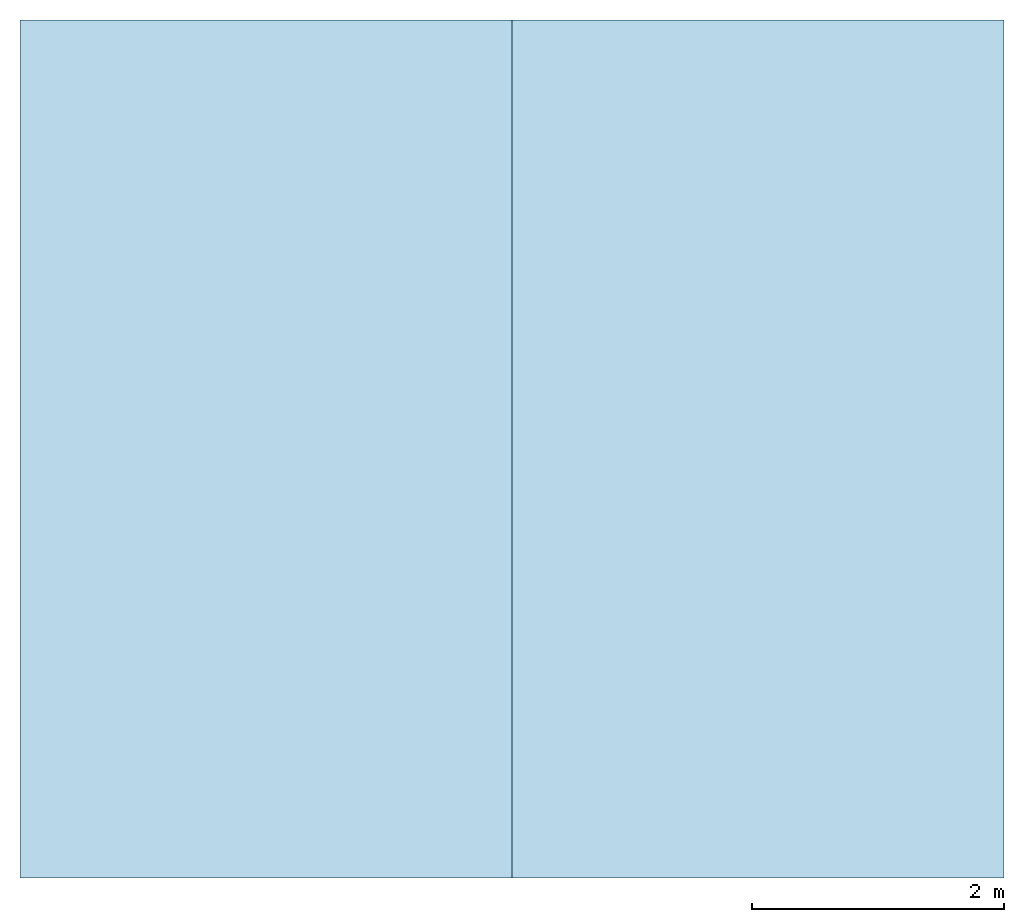
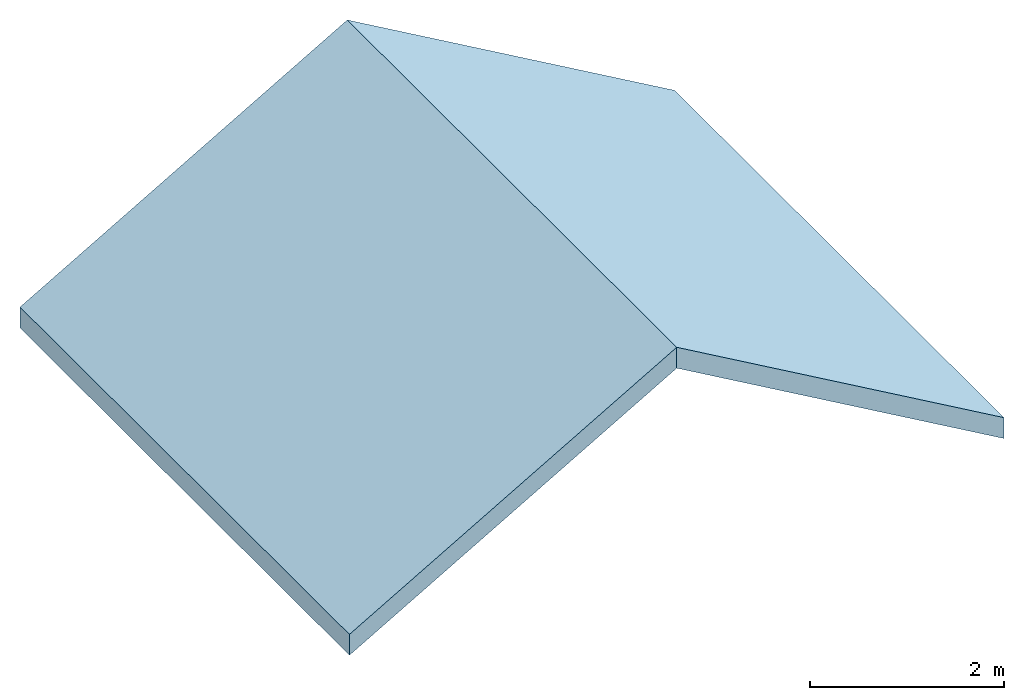
# One storey: 2 slabs, 1 element without a shape of its own.
"""IFC2X3 building model written with IfcOpenShell, lengths in millimetres."""

from ifc_helpers import new_model, entity, si_unit, converted_unit, derived_unit, direction, frame, frame_2d, origin, place, context, subcontext, project, spatial, rectangle, extrude, material, layer, layer_set, element, aggregate, save


model = new_model("IFC2X3")

# Units and contexts
model_context = context("Model", 3, precision=0.01, world=origin(), true_north=direction((6.12303176911189e-17, 1.0)))
body_context = subcontext(model_context, "Body", "Model", "MODEL_VIEW")
ifc_project = project(units=[si_unit("LENGTHUNIT", "METRE", prefix="MILLI"), si_unit("AREAUNIT", "SQUARE_METRE"), si_unit("VOLUMEUNIT", "CUBIC_METRE"), converted_unit("PLANEANGLEUNIT", "DEGREE", entity("IfcRatioMeasure", 0.0174532925199433), si_unit("PLANEANGLEUNIT", "RADIAN"), dimensions=[0, 0, 0, 0, 0, 0, 0]), si_unit("MASSUNIT", "GRAM", prefix="KILO"), si_unit("TIMEUNIT", "SECOND"), si_unit("FREQUENCYUNIT", "HERTZ"), si_unit("THERMODYNAMICTEMPERATUREUNIT", "DEGREE_CELSIUS"), derived_unit("THERMALTRANSMITTANCEUNIT", [(si_unit("MASSUNIT", "GRAM", prefix="KILO"), 1), (si_unit("THERMODYNAMICTEMPERATUREUNIT", "KELVIN"), -1), (si_unit("TIMEUNIT", "SECOND"), -3)]), derived_unit("VOLUMETRICFLOWRATEUNIT", [(si_unit("LENGTHUNIT", "METRE"), 3), (si_unit("TIMEUNIT", "SECOND"), -1)]), si_unit("ELECTRICCURRENTUNIT", "AMPERE"), si_unit("ELECTRICVOLTAGEUNIT", "VOLT"), si_unit("POWERUNIT", "WATT"), si_unit("FORCEUNIT", "NEWTON", prefix="KILO"), si_unit("ILLUMINANCEUNIT", "LUX"), si_unit("LUMINOUSFLUXUNIT", "LUMEN"), si_unit("LUMINOUSINTENSITYUNIT", "CANDELA"), derived_unit("USERDEFINED", [(si_unit("MASSUNIT", "GRAM", prefix="KILO"), -1), (si_unit("LENGTHUNIT", "METRE"), -2), (si_unit("TIMEUNIT", "SECOND"), 3), (si_unit("LUMINOUSFLUXUNIT", "LUMEN"), 1)]), derived_unit("LINEARVELOCITYUNIT", [(si_unit("LENGTHUNIT", "METRE"), 1), (si_unit("TIMEUNIT", "SECOND"), -1)]), si_unit("PRESSUREUNIT", "PASCAL"), derived_unit("USERDEFINED", [(si_unit("LENGTHUNIT", "METRE"), -2), (si_unit("MASSUNIT", "GRAM", prefix="KILO"), 1), (si_unit("TIMEUNIT", "SECOND"), -2)])], contexts=[model_context])

# Site, building, storey
site_placement = place(None, origin())
site = spatial("IfcSite", under=ifc_project, at=site_placement, CompositionType="ELEMENT")
building_placement = place(site_placement, origin())
building = spatial("IfcBuilding", under=site, at=building_placement, CompositionType="ELEMENT")
storey_placement = place(building_placement, frame((0.0, 0.0, 4000.0)))
storey = spatial("IfcBuildingStorey", under=building, at=storey_placement, Name="Level 1", CompositionType="ELEMENT", Elevation=4000.0)

# Roof, slabs
roof_placement = place(storey_placement, frame((-4953.60563367416, -2292.6654969841, 0.0)))
roof = element("IfcRoof", 1, at=roof_placement, inside=storey)
ifc_material_1 = material()
ifc_layer_1 = layer(ifc_material_1, 20.0)
ifc_material_2 = material()
ifc_layer_2 = layer(ifc_material_2, 195.0)
ifc_material_3 = material()
ifc_layer_3 = layer(ifc_material_3, 12.5)
ifc_layer_set = layer_set([ifc_layer_1, ifc_layer_2, ifc_layer_3])
slab_1_placement = place(roof_placement, origin())
slab_1 = element("IfcSlab", 2, at=slab_1_placement, material=ifc_layer_set, PredefinedType="ROOF", context=body_context, shape_type="SweptSolid", body=[
    extrude(rectangle(XDim=4503.33209967908, YDim=6800.0, at=frame_2d((-2.27373675443232e-13, 0.0), x_axis=(-1.0, 0.0))), frame((1950.0, 3400.0, 1125.83302491977), z_axis=(-0.5, 0.0, 0.866025403784439), x_axis=(0.866025403784439, 0.0, 0.5)), (0.5, 0.0, 0.866025403784439), 262.694372481279),
])
slab_2_placement = place(roof_placement, origin())
slab_2 = element("IfcSlab", 3, at=slab_2_placement, material=ifc_layer_set, PredefinedType="ROOF", context=body_context, shape_type="SweptSolid", body=[
    extrude(rectangle(XDim=6800.0, YDim=4503.33209967908, at=frame_2d((-2.27373675443232e-13, 0.0), x_axis=(0.0, -1.0))), frame((5850.0, 3400.0, 1125.83302491977), z_axis=(0.5, 0.0, 0.866025403784439), x_axis=(0.866025403784439, 0.0, -0.5)), (-0.5, 0.0, 0.866025403784439), 262.694372481279),
])
aggregate(roof, [slab_1, slab_2])

save(model, "model.ifc")
